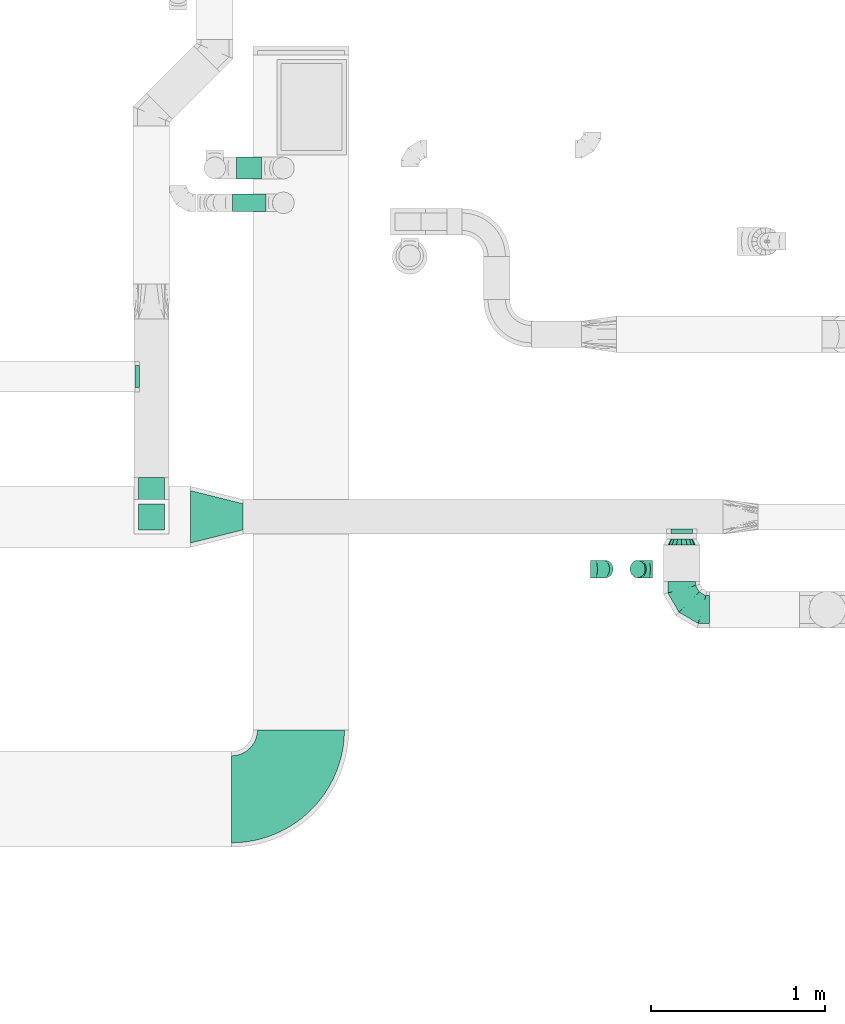
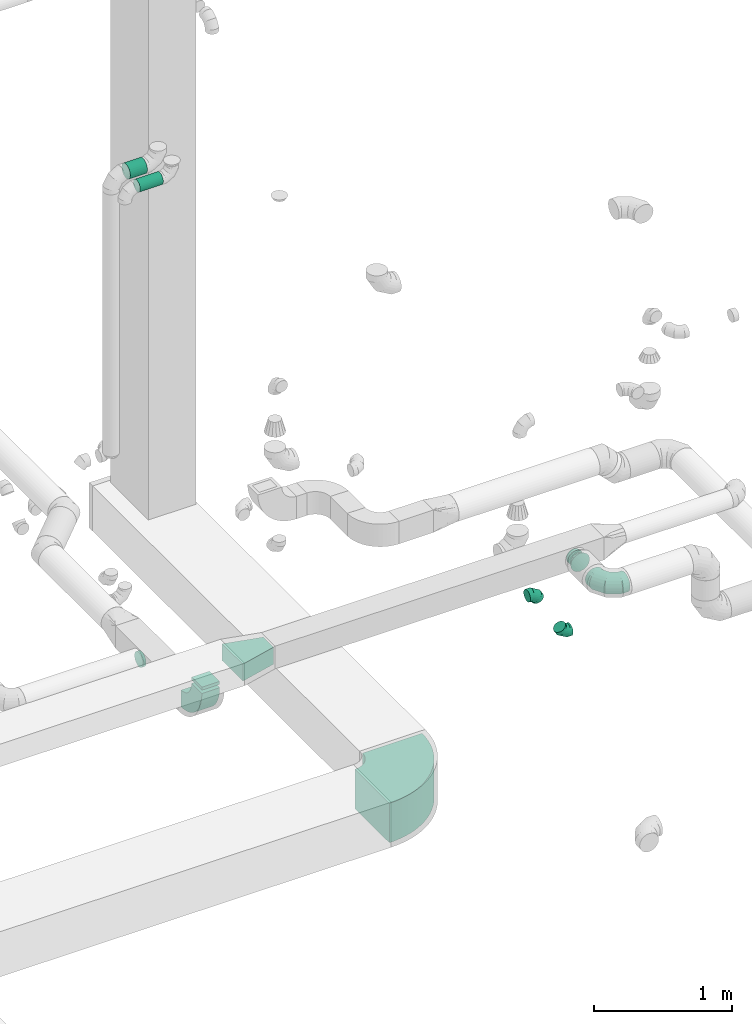
# One storey, part 72 of 97: 10 flow fittings, 2 flow segments.
"""IFC2X3 building model written with IfcOpenShell, lengths in millimetres."""

import ifcopenshell
import ifcopenshell.guid

model = None  # the IFC model being written
_history = None  # IfcOwnerHistory: only IFC2X3 demands one
_inside = {}  # id of a spatial element -> (the spatial element, [elements in it])
_under = {}  # id of a project, library or spatial element -> (it, [spatial elements below it])
_declared = {}  # id of a project -> (the project, [libraries it declares])
_typed = {}  # id of a type object -> (the type object, [elements of that type])
_made_of = {}  # id of a material, layer set ... -> (it, [elements and type objects made of it])


def new_model(schema):
    """Start an empty IFC model of exactly this schema.

    Asked for "IFC4X3", IfcOpenShell would pick the latest addendum, in which some entities
    have other attributes; the version numbers below select the first issue.
    IFC2X3 requires an IfcOwnerHistory on every rooted entity: one is made here for all.
    """
    global model, _history
    if schema == "IFC4X3":
        model = ifcopenshell.file(schema_version=(4, 3, 0, 0))
    else:
        model = ifcopenshell.file(schema=schema)
    _inside.clear()
    _under.clear()
    _declared.clear()
    _typed.clear()
    _made_of.clear()
    _history = None
    if model.schema == "IFC2X3":
        org = make("IfcOrganization", Name="unknown")
        user = make(
            "IfcPersonAndOrganization",
            ThePerson=make("IfcPerson", FamilyName="unknown"),
            TheOrganization=org,
        )
        app = make(
            "IfcApplication",
            ApplicationDeveloper=org,
            Version="unknown",
            ApplicationFullName="unknown",
            ApplicationIdentifier="unknown",
        )
        _history = make(
            "IfcOwnerHistory",
            OwningUser=user,
            OwningApplication=app,
            ChangeAction="ADDED",
            CreationDate=0,
        )
    return model


def make(cls, **values):
    """One entity of the class cls with the attributes given. An attribute that is None is left unset."""
    return model.create_entity(
        cls, **{name: value for name, value in values.items() if value is not None}
    )


def entity(cls, *values):
    """Any entity or typed value of the class cls, its attributes in the order of the schema. None: left unset."""
    e = model.create_entity(cls)
    for i, value in enumerate(values):
        if value is not None:
            e[i] = value
    return e


def rooted(cls, **values):
    """An entity with a GlobalId (a new one), such as an element, a storey or a relation."""
    return make(cls, GlobalId=ifcopenshell.guid.new(), OwnerHistory=_history, **values)


def si_unit(unit_type, name, prefix=None):
    """IfcSIUnit, for example si_unit("LENGTHUNIT", "METRE", prefix="MILLI")."""
    return make("IfcSIUnit", UnitType=unit_type, Prefix=prefix, Name=name)


def converted_unit(unit_type, name, factor, base, dimensions=None, offset=None):
    """IfcConversionBasedUnit, such as the inch: factor (a typed value) times the base unit."""
    return make(
        "IfcConversionBasedUnit"
        if offset is None
        else "IfcConversionBasedUnitWithOffset",
        ConversionOffset=offset,
        Dimensions=None
        if dimensions is None
        else entity("IfcDimensionalExponents", *dimensions),
        UnitType=unit_type,
        Name=name,
        ConversionFactor=make(
            "IfcMeasureWithUnit", ValueComponent=factor, UnitComponent=base
        ),
    )


def derived_unit(unit_type, elements):
    """IfcDerivedUnit: a product of units, each with its exponent."""
    return make(
        "IfcDerivedUnit",
        Elements=[
            make("IfcDerivedUnitElement", Unit=unit, Exponent=power)
            for unit, power in elements
        ],
        UnitType=unit_type,
    )


def assignment(units):
    """IfcUnitAssignment: the units of a project."""
    return None if units is None else make("IfcUnitAssignment", Units=units)


def point(xyz):
    """IfcCartesianPoint."""
    return None if xyz is None else make("IfcCartesianPoint", Coordinates=xyz)


def direction(xyz):
    """IfcDirection."""
    return None if xyz is None else make("IfcDirection", DirectionRatios=xyz)


def frame(location, z_axis=None, x_axis=None):
    """IfcAxis2Placement3D, a coordinate frame: its origin and axes. An axis left out is left unset."""
    return make(
        "IfcAxis2Placement3D",
        Location=point(location),
        Axis=direction(z_axis),
        RefDirection=direction(x_axis),
    )


def frame_2d(location, x_axis=None):
    """IfcAxis2Placement2D, a coordinate frame in the plane: its origin and x axis."""
    return make(
        "IfcAxis2Placement2D", Location=point(location), RefDirection=direction(x_axis)
    )


def origin():
    """The frame at (0, 0, 0) with its axes left unset."""
    return frame((0.0, 0.0, 0.0))


def origin_2d_with_axis():
    """The frame at (0, 0) in the plane with the x axis (1, 0) written out."""
    return frame_2d((0.0, 0.0), x_axis=(1.0, 0.0))


def place(relative_to, where):
    """IfcLocalPlacement: puts the frame where relative to a parent placement (None: the world)."""
    return make(
        "IfcLocalPlacement", PlacementRelTo=relative_to, RelativePlacement=where
    )


def context(
    kind, dimensions, precision=None, world=None, true_north=None, identifier=None
):
    """IfcGeometricRepresentationContext, for example the 3D "Model" context."""
    return make(
        "IfcGeometricRepresentationContext",
        ContextIdentifier=identifier,
        ContextType=kind,
        CoordinateSpaceDimension=dimensions,
        Precision=precision,
        WorldCoordinateSystem=world,
        TrueNorth=true_north,
    )


def subcontext(parent, identifier, kind, view, scale=None):
    """IfcGeometricRepresentationSubContext, for example "Body" below "Model"."""
    return make(
        "IfcGeometricRepresentationSubContext",
        ContextIdentifier=identifier,
        ContextType=kind,
        ParentContext=parent,
        TargetScale=scale,
        TargetView=view,
    )


def project(units=None, contexts=None):
    """IfcProject with its units and contexts."""
    return rooted(
        "IfcProject",
        Name="project",
        RepresentationContexts=contexts,
        UnitsInContext=assignment(units),
    )


def spatial(cls, under=None, at=None, **own):
    """A site, building, storey or space (cls), placed at a placement, below another one or the project."""
    s = rooted(cls, ObjectPlacement=at, **own)
    if under is not None:
        _under.setdefault(under.id(), (under, []))[1].append(s)
    return s


def polyline(points):
    """IfcPolyline through the points."""
    return make("IfcPolyline", Points=[point(p) for p in points])


def circle_curve(where, radius):
    """IfcCircle in the frame where."""
    return make("IfcCircle", Position=where, Radius=radius)


def parameter(value):
    """IfcParameterValue: where a trimmed curve begins or ends, as a parameter of its basis curve."""
    return model.create_entity("IfcParameterValue", value)


def trimmed(basis, trim1, trim2, sense, master):
    """IfcTrimmedCurve: the piece of a basis curve between two trims."""
    return make(
        "IfcTrimmedCurve",
        BasisCurve=basis,
        Trim1=trim1,
        Trim2=trim2,
        SenseAgreement=sense,
        MasterRepresentation=master,
    )


def segment(curve, same_sense, transition):
    """IfcCompositeCurveSegment."""
    return make(
        "IfcCompositeCurveSegment",
        Transition=transition,
        SameSense=same_sense,
        ParentCurve=curve,
    )


def composite_curve(segments, self_intersect=None):
    """IfcCompositeCurve: segments joined end to end."""
    return make("IfcCompositeCurve", Segments=segments, SelfIntersect=self_intersect)


def profile(cls, at=None, kind="AREA", **sizes):
    """A parametric profile (cls). Its sizes go by their IFC names, for example OverallWidth=200.0."""
    return make(cls, ProfileType=kind, Position=at, **sizes)


def rectangle(**sizes):
    """IfcRectangleProfileDef."""
    return profile("IfcRectangleProfileDef", **sizes)


def circle(**sizes):
    """IfcCircleProfileDef."""
    return profile("IfcCircleProfileDef", **sizes)


def outline(outer, holes=None, kind="AREA"):
    """IfcArbitraryClosedProfileDef: a profile drawn as a closed curve; with holes, ...WithVoids."""
    if holes is None:
        return make("IfcArbitraryClosedProfileDef", ProfileType=kind, OuterCurve=outer)
    return make(
        "IfcArbitraryProfileDefWithVoids",
        ProfileType=kind,
        OuterCurve=outer,
        InnerCurves=holes,
    )


def extrude(swept, where, along, depth):
    """IfcExtrudedAreaSolid: the profile swept, set in the frame where, extruded along a direction by depth."""
    return make(
        "IfcExtrudedAreaSolid",
        SweptArea=swept,
        Position=where,
        ExtrudedDirection=direction(along),
        Depth=depth,
    )


def faces_of(points, faces, orient=None, outer=None):
    """IfcFace entities. A face is a list of loops; a loop is a list of indices into points, from 0.

    orient and outer hold one flag for each loop. By default every Orientation is true, the
    first loop of a face is its IfcFaceOuterBound and the others are IfcFaceBound.
    """
    made = []
    for i, loops in enumerate(faces):
        bounds = []
        for j, loop in enumerate(loops):
            is_outer = j == 0 if outer is None else outer[i][j]
            bounds.append(
                make(
                    "IfcFaceOuterBound" if is_outer else "IfcFaceBound",
                    Bound=make("IfcPolyLoop", Polygon=[points[k] for k in loop]),
                    Orientation=True if orient is None else orient[i][j],
                )
            )
        made.append(make("IfcFace", Bounds=bounds))
    return made


def faceted_brep(points, faces, orient=None, outer=None, voids=None):
    """IfcFacetedBrep: a solid bounded by flat faces; with voids (closed shells), ...WithVoids."""
    shared = [point(p) for p in points]
    hull = make("IfcClosedShell", CfsFaces=faces_of(shared, faces, orient, outer))
    if voids is None:
        return make("IfcFacetedBrep", Outer=hull)
    return make(
        "IfcFacetedBrepWithVoids",
        Outer=hull,
        Voids=[
            make(cls, CfsFaces=faces_of(shared, fs, o, b)) for cls, fs, o, b in voids
        ],
    )


def shape(context_of_items, identifier, shape_type, items):
    """IfcShapeRepresentation: the items that make up one representation, for example the "Body"."""
    return make(
        "IfcShapeRepresentation",
        ContextOfItems=context_of_items,
        RepresentationIdentifier=identifier,
        RepresentationType=shape_type,
        Items=items,
    )


def source(mapping_origin, context_of_items, identifier, shape_type, items):
    """IfcRepresentationMap: a shape defined once, which mapped items show again and again."""
    return make(
        "IfcRepresentationMap",
        MappingOrigin=mapping_origin,
        MappedRepresentation=shape(context_of_items, identifier, shape_type, items),
    )


def transform(
    local_origin,
    x_axis=None,
    y_axis=None,
    z_axis=None,
    scale=None,
    scale2=None,
    scale3=None,
    uniform=True,
):
    """IfcCartesianTransformationOperator3D, or its non-uniform kind. x_axis, y_axis, z_axis: its Axis1, 2, 3."""
    if uniform:
        return make(
            "IfcCartesianTransformationOperator3D",
            Axis1=direction(x_axis),
            Axis2=direction(y_axis),
            LocalOrigin=point(local_origin),
            Scale=scale,
            Axis3=direction(z_axis),
        )
    return make(
        "IfcCartesianTransformationOperator3DnonUniform",
        Axis1=direction(x_axis),
        Axis2=direction(y_axis),
        LocalOrigin=point(local_origin),
        Scale=scale,
        Axis3=direction(z_axis),
        Scale2=scale2,
        Scale3=scale3,
    )


def mapped(mapping_source, mapping_target):
    """IfcMappedItem: shows the shape of a source again, moved by a transform."""
    return make(
        "IfcMappedItem", MappingSource=mapping_source, MappingTarget=mapping_target
    )


def material(Name=None, Category=None):
    """IfcMaterial."""
    return make("IfcMaterial", Name=Name, Category=Category)


def made_of(thing, what):
    """Note that an element or type object is made of a material, layer set ...; save() writes the relation."""
    if what is not None:
        _made_of.setdefault(what.id(), (what, []))[1].append(thing)
    return thing


def type_object(cls, material=None, **own):
    """A type object (cls), such as IfcWallType, which elements share."""
    return made_of(rooted(cls, **own), material)


def type_shapes(of_type, sources):
    """Give a type object the sources (RepresentationMaps) that its elements show as mapped items."""
    of_type.RepresentationMaps = sources


def element(
    cls,
    number,
    at=None,
    inside=None,
    cuts=None,
    type_object=None,
    material=None,
    context=None,
    identifier="Body",
    shape_type=None,
    held_by="IfcProductDefinitionShape",
    body=None,
    shapes=None,
    **own,
):
    """One element of the class cls, such as IfcWall. Its Tag is "e" and its number.

    at: its placement. inside: the storey or other place that contains it. cuts: it is an
    opening in that element (IfcRelVoidsElement). A single representation is given by context,
    identifier, shape_type and body (its items); several are given by shapes. held_by: the class
    of the entity that holds the representations. save() writes the other relations.
    """
    e = rooted(cls, Tag="e%d" % number, ObjectPlacement=at, **own)
    if body is not None:
        shapes = [shape(context, identifier, shape_type, body)]
    if shapes is not None:
        e.Representation = make(held_by, Representations=shapes)
    if inside is not None:
        _inside.setdefault(inside.id(), (inside, []))[1].append(e)
    if cuts is not None:
        rooted(
            "IfcRelVoidsElement", RelatingBuildingElement=cuts, RelatedOpeningElement=e
        )
    if type_object is not None:
        _typed.setdefault(type_object.id(), (type_object, []))[1].append(e)
    return made_of(e, material)


def aggregate(whole, parts):
    """IfcRelAggregates: a whole, such as a stair, and the parts it consists of."""
    return rooted("IfcRelAggregates", RelatingObject=whole, RelatedObjects=parts)


def save(model, path):
    """Write the relations noted so far, then the file.

    IfcRelAggregates (storeys below a building ...), IfcRelContainedInSpatialStructure (elements
    in a storey), IfcRelDefinesByType, IfcRelAssociatesMaterial and IfcRelDeclares: one each for
    every whole, place, type object, material and project.
    """
    for whole, parts in _under.values():
        aggregate(whole, parts)
    for where, things in _inside.values():
        rooted(
            "IfcRelContainedInSpatialStructure",
            RelatedElements=things,
            RelatingStructure=where,
        )
    for kind, things in _typed.values():
        rooted("IfcRelDefinesByType", RelatedObjects=things, RelatingType=kind)
    for what, things in _made_of.values():
        rooted("IfcRelAssociatesMaterial", RelatedObjects=things, RelatingMaterial=what)
    for by, libraries in _declared.values():
        rooted("IfcRelDeclares", RelatingContext=by, RelatedDefinitions=libraries)
    model.write(path)


model = new_model("IFC2X3")

# Units and contexts
model_context = context("Model", 3, precision=0.01, world=origin(), true_north=direction((6.12303176911189e-17, 1.0)))
body_context = subcontext(model_context, "Body", "Model", "MODEL_VIEW")
ifc_project = project(units=[si_unit("LENGTHUNIT", "METRE", prefix="MILLI"), si_unit("AREAUNIT", "SQUARE_METRE"), si_unit("VOLUMEUNIT", "CUBIC_METRE"), converted_unit("PLANEANGLEUNIT", "DEGREE", entity("IfcRatioMeasure", 0.0174532925199433), si_unit("PLANEANGLEUNIT", "RADIAN"), dimensions=[0, 0, 0, 0, 0, 0, 0]), si_unit("MASSUNIT", "GRAM", prefix="KILO"), derived_unit("MASSDENSITYUNIT", [(si_unit("MASSUNIT", "GRAM", prefix="KILO"), 1), (si_unit("LENGTHUNIT", "METRE"), -3)]), derived_unit("MOMENTOFINERTIAUNIT", [(si_unit("LENGTHUNIT", "METRE"), 4)]), si_unit("TIMEUNIT", "SECOND"), si_unit("FREQUENCYUNIT", "HERTZ"), si_unit("THERMODYNAMICTEMPERATUREUNIT", "DEGREE_CELSIUS"), derived_unit("THERMALTRANSMITTANCEUNIT", [(si_unit("MASSUNIT", "GRAM", prefix="KILO"), 1), (si_unit("THERMODYNAMICTEMPERATUREUNIT", "KELVIN"), -1), (si_unit("TIMEUNIT", "SECOND"), -3)]), derived_unit("VOLUMETRICFLOWRATEUNIT", [(si_unit("LENGTHUNIT", "METRE"), 3), (si_unit("TIMEUNIT", "SECOND"), -1)]), derived_unit("MASSFLOWRATEUNIT", [(si_unit("MASSUNIT", "GRAM", prefix="KILO"), 1), (si_unit("TIMEUNIT", "SECOND"), -1)]), derived_unit("ROTATIONALFREQUENCYUNIT", [(si_unit("TIMEUNIT", "SECOND"), -1)]), si_unit("ELECTRICCURRENTUNIT", "AMPERE"), si_unit("ELECTRICVOLTAGEUNIT", "VOLT"), si_unit("POWERUNIT", "WATT"), si_unit("FORCEUNIT", "NEWTON", prefix="KILO"), si_unit("ILLUMINANCEUNIT", "LUX"), si_unit("LUMINOUSFLUXUNIT", "LUMEN"), si_unit("LUMINOUSINTENSITYUNIT", "CANDELA"), derived_unit("USERDEFINED", [(si_unit("MASSUNIT", "GRAM", prefix="KILO"), -1), (si_unit("LENGTHUNIT", "METRE"), -2), (si_unit("TIMEUNIT", "SECOND"), 3), (si_unit("LUMINOUSFLUXUNIT", "LUMEN"), 1)]), derived_unit("LINEARVELOCITYUNIT", [(si_unit("LENGTHUNIT", "METRE"), 1), (si_unit("TIMEUNIT", "SECOND"), -1)]), si_unit("PRESSUREUNIT", "PASCAL"), derived_unit("USERDEFINED", [(si_unit("LENGTHUNIT", "METRE"), -2), (si_unit("MASSUNIT", "GRAM", prefix="KILO"), 1), (si_unit("TIMEUNIT", "SECOND"), -2)]), derived_unit("LINEARFORCEUNIT", [(si_unit("MASSUNIT", "GRAM", prefix="KILO"), 1), (si_unit("LENGTHUNIT", "METRE"), 1), (si_unit("TIMEUNIT", "SECOND"), -2), (si_unit("LENGTHUNIT", "METRE"), -1)]), derived_unit("PLANARFORCEUNIT", [(si_unit("MASSUNIT", "GRAM", prefix="KILO"), 1), (si_unit("LENGTHUNIT", "METRE"), 1), (si_unit("TIMEUNIT", "SECOND"), -2), (si_unit("LENGTHUNIT", "METRE"), -2)])], contexts=[model_context])

# Site, building, storey
site_placement = place(None, origin())
site = spatial("IfcSite", under=ifc_project, at=site_placement, CompositionType="ELEMENT")
building_placement = place(site_placement, origin())
building = spatial("IfcBuilding", under=site, at=building_placement, CompositionType="ELEMENT")
storey_placement = place(building_placement, frame((0.0, 0.0, -4900.0)))
storey = spatial("IfcBuildingStorey", under=building, at=storey_placement, CompositionType="ELEMENT", Elevation=-4900.0)

# Flow segments
duct_segment_type = type_object("IfcDuctSegmentType", PredefinedType="NOTDEFINED")
flow_segment_1_placement = place(storey_placement, frame((67594.25, 11926.94, 7348.4)))
element("IfcFlowSegment", 1, at=flow_segment_1_placement, inside=storey, type_object=duct_segment_type, context=body_context, shape_type="SweptSolid", body=[
    extrude(circle(Radius=50.0, at=origin_2d_with_axis()), frame((0.0, 51.6, 51.6), z_axis=(1.0, 0.0, 0.0), x_axis=(0.0, -1.0, 0.0)), (0.0, 0.0, 1.0), 193.744460000044),
])
flow_segment_2_placement = place(storey_placement, frame((67619.25, 12114.64, 7335.9)))
element("IfcFlowSegment", 2, at=flow_segment_2_placement, inside=storey, type_object=duct_segment_type, context=body_context, shape_type="SweptSolid", body=[
    extrude(circle(Radius=62.5, at=origin_2d_with_axis()), frame((0.0, 64.1, 64.1), z_axis=(1.0, 0.0, 0.0), x_axis=(0.0, -1.0, 0.0)), (0.0, 0.0, 1.0), 143.74446000002),
])

# Flow fittings
ifc_material = material()
duct_fitting_type_1 = type_object("IfcDuctFittingType", PredefinedType="NOTDEFINED", material=ifc_material)
shared_shape_1 = source(origin(), body_context, "Body", "SweptSolid", [
    extrude(outline(polyline([(-181.9, -109.14), (127.33, -109.14), (163.71, 36.38), (-109.14, 181.9), (-181.9, -109.14)])), frame((150.0, 0.0, -75.0), z_axis=(0.0, 0.0, 1.0), x_axis=(0.970142500145332, 0.242535625036331, 0.0)), (0.0, 0.0, 1.0), 150.0),
])
type_shapes(duct_fitting_type_1, [shared_shape_1])
flow_fitting_1_placement = place(storey_placement, frame((67355.27, 10174.06, 4350.0)))
element("IfcFlowFitting", 3, at=flow_fitting_1_placement, inside=storey, type_object=duct_fitting_type_1, material=ifc_material, context=body_context, shape_type="MappedRepresentation", body=[
    mapped(shared_shape_1, transform((0.0, 0.0, 0.0), scale=1.0)),
])
duct_fitting_type_2 = type_object("IfcDuctFittingType", PredefinedType="NOTDEFINED", material=ifc_material)
shared_shape_2 = source(origin(), body_context, "Body", "SweptSolid", [
    extrude(rectangle(XDim=26.0960000000062, YDim=150.0, at=origin_2d_with_axis()), frame((6.95, 0.0, -75.0)), (0.0, 0.0, 1.0), 150.0),
])
type_shapes(duct_fitting_type_2, [shared_shape_2])
flow_fitting_2_placement = place(storey_placement, frame((67129.73, 10174.06, 4275.0), z_axis=(0.0, 1.0, 0.0), x_axis=(0.0, 0.0, -1.0)))
element("IfcFlowFitting", 4, at=flow_fitting_2_placement, inside=storey, type_object=duct_fitting_type_2, material=ifc_material, context=body_context, shape_type="MappedRepresentation", body=[
    mapped(shared_shape_2, transform((0.0, 0.0, 0.0), scale=1.0)),
])
duct_fitting_type_3 = type_object("IfcDuctFittingType", PredefinedType="NOTDEFINED", material=ifc_material)
shared_shape_3 = source(origin(), body_context, "Body", "Brep", [
    faceted_brep([(-160.0, 0.0, -80.0), (-160.0, -20.71, -77.27), (-160.0, -40.0, -69.28), (-160.0, -56.57, -56.57), (-160.0, -69.28, -40.0), (-160.0, -77.27, -20.71), (-160.0, -80.0, 0.0), (-160.0, -77.27, 20.71), (-160.0, -69.28, 40.0), (-160.0, -56.57, 56.57), (-160.0, -40.0, 69.28), (-160.0, -20.71, 77.27), (-160.0, 0.0, 80.0), (-160.0, 20.71, 77.27), (-160.0, 40.0, 69.28), (-160.0, 56.57, 56.57), (-160.0, 69.28, 40.0), (-160.0, 77.27, 20.71), (-160.0, 80.0, 0.0), (-160.0, 77.27, -20.71), (-160.0, 69.28, -40.0), (-160.0, 56.57, -56.57), (-160.0, 40.0, -69.28), (-160.0, 20.71, -77.27), (-122.68, 20.71, 77.27), (-127.85, 40.0, 69.28), (-117.13, 0.0, 80.0), (-132.29, 56.57, 56.57), (-137.83, 77.27, 20.71), (-138.56, 80.0, 0.0), (-135.69, 69.28, 40.0), (-135.69, 69.28, -40.0), (-132.29, 56.57, -56.57), (-137.83, 77.27, -20.71), (-122.68, 20.71, -77.27), (-117.13, 0.0, -80.0), (-127.85, 40.0, -69.28), (-111.58, -20.71, -77.27), (-106.41, -40.0, -69.28), (-101.97, -56.57, -56.57), (-98.56, -69.28, -40.0), (-96.42, -77.27, -20.71), (-95.69, -80.0, 0.0), (-96.42, -77.27, 20.71), (-98.56, -69.28, 40.0), (-101.97, -56.57, 56.57), (-106.41, -40.0, 69.28), (-111.58, -20.71, 77.27), (-58.03, 58.03, 77.27), (-72.15, 72.15, 69.28), (-42.87, 42.87, 80.0), (-84.28, 84.28, 56.57), (-93.59, 93.59, 40.0), (-99.44, 99.44, 20.71), (-101.44, 101.44, 0.0), (-99.44, 99.44, -20.71), (-93.59, 93.59, -40.0), (-84.28, 84.28, -56.57), (-58.03, 58.03, -77.27), (-42.87, 42.87, -80.0), (-72.15, 72.15, -69.28), (-27.71, 27.71, -77.27), (-13.59, 13.59, -69.28), (-1.46, 1.46, -56.57), (7.85, -7.85, -40.0), (13.7, -13.7, -20.71), (15.69, -15.69, 0.0), (13.7, -13.7, 20.71), (7.85, -7.85, 40.0), (-1.46, 1.46, 56.57), (-13.59, 13.59, 69.28), (-27.71, 27.71, 77.27), (-20.71, 122.68, 77.27), (-40.0, 127.85, 69.28), (0.0, 117.13, 80.0), (-56.57, 132.29, 56.57), (-69.28, 135.69, 40.0), (-77.27, 137.83, 20.71), (-80.0, 138.56, 0.0), (-77.27, 137.83, -20.71), (-69.28, 135.69, -40.0), (-56.57, 132.29, -56.57), (-20.71, 122.68, -77.27), (0.0, 117.13, -80.0), (-40.0, 127.85, -69.28), (20.71, 111.58, -77.27), (40.0, 106.41, -69.28), (56.57, 101.97, -56.57), (69.28, 98.56, -40.0), (77.27, 96.42, -20.71), (80.0, 95.69, 0.0), (77.27, 96.42, 20.71), (69.28, 98.56, 40.0), (56.57, 101.97, 56.57), (40.0, 106.41, 69.28), (20.71, 111.58, 77.27), (-20.71, 160.0, -77.27), (-40.0, 160.0, -69.28), (-56.57, 160.0, -56.57), (-69.28, 160.0, -40.0), (-77.27, 160.0, -20.71), (-80.0, 160.0, 0.0), (-77.27, 160.0, 20.71), (-69.28, 160.0, 40.0), (-56.57, 160.0, 56.57), (-40.0, 160.0, 69.28), (-20.71, 160.0, 77.27), (0.0, 160.0, 80.0), (20.71, 160.0, 77.27), (40.0, 160.0, 69.28), (56.57, 160.0, 56.57), (69.28, 160.0, 40.0), (77.27, 160.0, 20.71), (80.0, 160.0, 0.0), (77.27, 160.0, -20.71), (69.28, 160.0, -40.0), (56.57, 160.0, -56.57), (40.0, 160.0, -69.28), (20.71, 160.0, -77.27), (0.0, 160.0, -80.0)], [[[0, 1, 2, 3, 4, 5, 6, 7, 8, 9, 10, 11, 12, 13, 14, 15, 16, 17, 18, 19, 20, 21, 22, 23]], [[24, 25, 14, 13]], [[26, 24, 13, 12]], [[14, 25, 27, 15]], [[28, 29, 18, 17]], [[30, 28, 17, 16]], [[15, 27, 30, 16]], [[20, 31, 32, 21]], [[33, 31, 20, 19]], [[18, 29, 33, 19]], [[34, 35, 0, 23]], [[36, 34, 23, 22]], [[32, 36, 22, 21]], [[1, 0, 35, 37]], [[2, 1, 37, 38]], [[3, 2, 38, 39]], [[5, 4, 40, 41]], [[6, 5, 41, 42]], [[39, 40, 4, 3]], [[6, 42, 43, 7]], [[7, 43, 44, 8]], [[8, 44, 45, 9]], [[9, 45, 46, 10]], [[10, 46, 47, 11]], [[26, 12, 11, 47]], [[48, 49, 25, 24]], [[50, 48, 24, 26]], [[27, 25, 49, 51]], [[52, 53, 28, 30]], [[51, 52, 30, 27]], [[29, 28, 53, 54]], [[55, 56, 31, 33]], [[54, 55, 33, 29]], [[32, 31, 56, 57]], [[58, 59, 35, 34]], [[60, 58, 34, 36]], [[57, 60, 36, 32]], [[37, 35, 59, 61]], [[38, 37, 61, 62]], [[39, 38, 62, 63]], [[41, 40, 64, 65]], [[42, 41, 65, 66]], [[63, 64, 40, 39]], [[43, 42, 66, 67]], [[44, 43, 67, 68]], [[68, 69, 45, 44]], [[46, 45, 69, 70]], [[47, 46, 70, 71]], [[26, 47, 71, 50]], [[72, 73, 49, 48]], [[74, 72, 48, 50]], [[51, 49, 73, 75]], [[76, 77, 53, 52]], [[75, 76, 52, 51]], [[54, 53, 77, 78]], [[79, 80, 56, 55]], [[78, 79, 55, 54]], [[57, 56, 80, 81]], [[82, 83, 59, 58]], [[84, 82, 58, 60]], [[81, 84, 60, 57]], [[61, 59, 83, 85]], [[62, 61, 85, 86]], [[63, 62, 86, 87]], [[65, 64, 88, 89]], [[66, 65, 89, 90]], [[87, 88, 64, 63]], [[67, 66, 90, 91]], [[68, 67, 91, 92]], [[92, 93, 69, 68]], [[70, 69, 93, 94]], [[71, 70, 94, 95]], [[50, 71, 95, 74]], [[96, 97, 98, 99, 100, 101, 102, 103, 104, 105, 106, 107, 108, 109, 110, 111, 112, 113, 114, 115, 116, 117, 118, 119]], [[72, 74, 107, 106]], [[73, 72, 106, 105]], [[75, 73, 105, 104]], [[77, 76, 103, 102]], [[78, 77, 102, 101]], [[75, 104, 103, 76]], [[78, 101, 100, 79]], [[79, 100, 99, 80]], [[80, 99, 98, 81]], [[84, 97, 96, 82]], [[82, 96, 119, 83]], [[84, 81, 98, 97]], [[118, 117, 86, 85]], [[119, 118, 85, 83]], [[116, 87, 86, 117]], [[88, 115, 114, 89]], [[89, 114, 113, 90]], [[115, 88, 87, 116]], [[112, 111, 92, 91]], [[113, 112, 91, 90]], [[111, 110, 93, 92]], [[95, 94, 109, 108]], [[74, 95, 108, 107]], [[110, 109, 94, 93]]]),
])
type_shapes(duct_fitting_type_3, [shared_shape_3])
flow_fitting_3_placement = place(storey_placement, frame((70177.23, 9641.0, 4350.0), z_axis=(0.0, 0.0, 1.0), x_axis=(0.0, -1.0, 0.0)))
element("IfcFlowFitting", 5, at=flow_fitting_3_placement, inside=storey, type_object=duct_fitting_type_3, material=ifc_material, context=body_context, shape_type="MappedRepresentation", body=[
    mapped(shared_shape_3, transform((0.0, 0.0, 0.0), scale=1.0)),
])
duct_fitting_type_4 = type_object("IfcDuctFittingType", PredefinedType="NOTDEFINED", material=ifc_material)
shared_shape_4 = source(origin(), body_context, "Body", "Brep", [
    faceted_brep([(20.0, 0.0, -62.5), (20.0, 16.18, -60.37), (20.0, 31.25, -54.13), (20.0, 44.19, -44.19), (20.0, 54.13, -31.25), (20.0, 60.37, -16.18), (20.0, 62.5, 0.0), (20.0, 60.37, 16.18), (20.0, 54.13, 31.25), (20.0, 44.19, 44.19), (20.0, 31.25, 54.13), (20.0, 16.18, 60.37), (20.0, 0.0, 62.5), (20.0, -16.18, 60.37), (20.0, -31.25, 54.13), (20.0, -44.19, 44.19), (20.0, -54.13, 31.25), (20.0, -60.37, 16.18), (20.0, -62.5, 0.0), (20.0, -60.37, -16.18), (20.0, -54.13, -31.25), (20.0, -44.19, -44.19), (20.0, -31.25, -54.13), (20.0, -16.18, -60.37), (0.0, 0.0, 62.5), (-6.1, 0.0, 62.5), (-6.1, -16.18, 60.37), (0.0, -16.18, 60.37), (-6.1, -31.25, 54.13), (0.0, -31.25, 54.13), (0.0, -44.19, 44.19), (-6.1, -44.19, 44.19), (0.0, -54.13, 31.25), (-6.1, -54.13, 31.25), (-6.1, -60.37, 16.18), (0.0, -60.37, 16.18), (-6.1, -62.5, 0.0), (0.0, -62.5, 0.0), (-6.1, -60.37, -16.18), (0.0, -60.37, -16.18), (-6.1, -54.13, -31.25), (0.0, -54.13, -31.25), (0.0, -44.19, -44.19), (-6.1, -44.19, -44.19), (0.0, -31.25, -54.13), (-6.1, -31.25, -54.13), (-6.1, -16.18, -60.37), (0.0, -16.18, -60.37), (-6.1, 0.0, -62.5), (0.0, 0.0, -62.5), (-6.1, 16.18, -60.37), (0.0, 16.18, -60.37), (-6.1, 31.25, -54.13), (0.0, 31.25, -54.13), (0.0, 44.19, -44.19), (-6.1, 44.19, -44.19), (0.0, 54.13, -31.25), (-6.1, 54.13, -31.25), (-6.1, 60.37, -16.18), (0.0, 60.37, -16.18), (-6.1, 62.5, 0.0), (0.0, 62.5, 0.0), (-6.1, 60.37, 16.18), (0.0, 60.37, 16.18), (-6.1, 54.13, 31.25), (0.0, 54.13, 31.25), (0.0, 44.19, 44.19), (-6.1, 44.19, 44.19), (0.0, 31.25, 54.13), (-6.1, 31.25, 54.13), (-6.1, 16.18, 60.37), (0.0, 16.18, 60.37)], [[[0, 1, 2, 3, 4, 5, 6, 7, 8, 9, 10, 11, 12, 13, 14, 15, 16, 17, 18, 19, 20, 21, 22, 23]], [[13, 12, 24, 25, 26, 27]], [[14, 13, 27, 26, 28, 29]], [[30, 15, 14, 29, 28, 31]], [[17, 16, 32, 33, 34, 35]], [[18, 17, 35, 34, 36, 37]], [[32, 16, 15, 30, 31, 33]], [[19, 18, 37, 36, 38, 39]], [[20, 19, 39, 38, 40, 41]], [[42, 21, 20, 41, 40, 43]], [[23, 22, 44, 45, 46, 47]], [[0, 23, 47, 46, 48, 49]], [[44, 22, 21, 42, 43, 45]], [[1, 0, 49, 48, 50, 51]], [[2, 1, 51, 50, 52, 53]], [[54, 3, 2, 53, 52, 55]], [[5, 4, 56, 57, 58, 59]], [[6, 5, 59, 58, 60, 61]], [[56, 4, 3, 54, 55, 57]], [[7, 6, 61, 60, 62, 63]], [[8, 7, 63, 62, 64, 65]], [[66, 9, 8, 65, 64, 67]], [[11, 10, 68, 69, 70, 71]], [[12, 11, 71, 70, 25, 24]], [[68, 10, 9, 66, 67, 69]], [[46, 45, 43, 40, 38, 36, 34, 33, 31, 28, 26, 25, 70, 69, 67, 64, 62, 60, 58, 57, 55, 52, 50, 48]]]),
])
type_shapes(duct_fitting_type_4, [shared_shape_4])
flow_fitting_4_placement = place(storey_placement, frame((67054.73, 10980.22, 4000.0), z_axis=(0.0, 0.0, -1.0), x_axis=(-1.0, 0.0, 0.0)))
element("IfcFlowFitting", 6, at=flow_fitting_4_placement, inside=storey, type_object=duct_fitting_type_4, material=ifc_material, context=body_context, shape_type="MappedRepresentation", body=[
    mapped(shared_shape_4, transform((0.0, 0.0, 0.0), scale=1.0)),
])
duct_fitting_type_5 = type_object("IfcDuctFittingType", PredefinedType="NOTDEFINED", material=ifc_material)
shared_shape_5 = source(origin(), body_context, "Body", "Brep", [
    faceted_brep([(-57.74, 0.0, -50.0), (-57.74, -12.94, -48.3), (-57.74, -25.0, -43.3), (-57.74, -35.36, -35.36), (-57.74, -43.3, -25.0), (-57.74, -48.3, -12.94), (-57.74, -50.0, 0.0), (-57.74, -48.3, 12.94), (-57.74, -43.3, 25.0), (-57.74, -35.36, 35.36), (-57.74, -25.0, 43.3), (-57.74, -12.94, 48.3), (-57.74, 0.0, 50.0), (-57.74, 12.94, 48.3), (-57.74, 25.0, 43.3), (-57.74, 35.36, 35.36), (-57.74, 43.3, 25.0), (-57.74, 48.3, 12.94), (-57.74, 50.0, 0.0), (-57.74, 48.3, -12.94), (-57.74, 43.3, -25.0), (-57.74, 35.36, -35.36), (-57.74, 25.0, -43.3), (-57.74, 12.94, -48.3), (-34.41, 12.94, 48.3), (-37.64, 25.0, 43.3), (-30.94, 0.0, 50.0), (-40.41, 35.36, 35.36), (-43.88, 48.3, 12.94), (-44.34, 50.0, 0.0), (-42.54, 43.3, 25.0), (-42.54, 43.3, -25.0), (-40.41, 35.36, -35.36), (-43.88, 48.3, -12.94), (-34.41, 12.94, -48.3), (-30.94, 0.0, -50.0), (-37.64, 25.0, -43.3), (-27.47, -12.94, -48.3), (-24.24, -25.0, -43.3), (-21.47, -35.36, -35.36), (-19.34, -43.3, -25.0), (-18.0, -48.3, -12.94), (-17.54, -50.0, 0.0), (-18.0, -48.3, 12.94), (-19.34, -43.3, 25.0), (-21.47, -35.36, 35.36), (-24.24, -25.0, 43.3), (-27.47, -12.94, 48.3), (6.0, 36.27, 48.3), (-2.83, 45.1, 43.3), (15.47, 26.79, 50.0), (-10.41, 52.68, 35.36), (-16.23, 58.49, 25.0), (-19.89, 62.15, 12.94), (-21.13, 63.4, 0.0), (-19.89, 62.15, -12.94), (-16.23, 58.49, -25.0), (-10.41, 52.68, -35.36), (6.0, 36.27, -48.3), (15.47, 26.79, -50.0), (-2.83, 45.1, -43.3), (24.94, 17.32, -48.3), (33.77, 8.49, -43.3), (41.35, 0.91, -35.36), (47.17, -4.9, -25.0), (50.83, -8.56, -12.94), (52.07, -9.81, 0.0), (50.83, -8.56, 12.94), (47.17, -4.9, 25.0), (41.35, 0.91, 35.36), (33.77, 8.49, 43.3), (24.94, 17.32, 48.3), (28.87, 50.0, 50.0), (17.66, 56.47, 48.3), (7.22, 62.5, 43.3), (-1.75, 67.68, 35.36), (-8.63, 71.65, 25.0), (-12.96, 74.15, 12.94), (-14.43, 75.0, 0.0), (-12.96, 74.15, -12.94), (-8.63, 71.65, -25.0), (-1.75, 67.68, -35.36), (17.66, 56.47, -48.3), (28.87, 50.0, -50.0), (7.22, 62.5, -43.3), (40.07, 43.53, -48.3), (50.52, 37.5, -43.3), (59.49, 32.32, -35.36), (66.37, 28.35, -25.0), (70.69, 25.85, -12.94), (72.17, 25.0, 0.0), (70.69, 25.85, 12.94), (66.37, 28.35, 25.0), (59.49, 32.32, 35.36), (50.52, 37.5, 43.3), (40.07, 43.53, 48.3)], [[[0, 1, 2, 3, 4, 5, 6, 7, 8, 9, 10, 11, 12, 13, 14, 15, 16, 17, 18, 19, 20, 21, 22, 23]], [[24, 25, 14, 13]], [[26, 24, 13, 12]], [[14, 25, 27, 15]], [[28, 29, 18, 17]], [[30, 28, 17, 16]], [[15, 27, 30, 16]], [[20, 31, 32, 21]], [[33, 31, 20, 19]], [[18, 29, 33, 19]], [[34, 35, 0, 23]], [[36, 34, 23, 22]], [[32, 36, 22, 21]], [[2, 1, 37, 38]], [[3, 2, 38, 39]], [[0, 35, 37, 1]], [[5, 4, 40, 41]], [[6, 5, 41, 42]], [[3, 39, 40, 4]], [[6, 42, 43, 7]], [[7, 43, 44, 8]], [[8, 44, 45, 9]], [[10, 46, 47, 11]], [[11, 47, 26, 12]], [[10, 9, 45, 46]], [[48, 49, 25, 24]], [[50, 48, 24, 26]], [[27, 25, 49, 51]], [[52, 53, 28, 30]], [[51, 52, 30, 27]], [[29, 28, 53, 54]], [[55, 56, 31, 33]], [[54, 55, 33, 29]], [[57, 32, 31, 56]], [[58, 59, 35, 34]], [[60, 58, 34, 36]], [[57, 60, 36, 32]], [[37, 35, 59, 61]], [[38, 37, 61, 62]], [[39, 38, 62, 63]], [[41, 40, 64, 65]], [[42, 41, 65, 66]], [[63, 64, 40, 39]], [[43, 42, 66, 67]], [[44, 43, 67, 68]], [[68, 69, 45, 44]], [[46, 45, 69, 70]], [[47, 46, 70, 71]], [[26, 47, 71, 50]], [[48, 50, 72, 73]], [[49, 48, 73, 74]], [[51, 49, 74, 75]], [[53, 52, 76, 77]], [[54, 53, 77, 78]], [[51, 75, 76, 52]], [[54, 78, 79, 55]], [[55, 79, 80, 56]], [[56, 80, 81, 57]], [[82, 83, 59, 58]], [[84, 82, 58, 60]], [[60, 57, 81, 84]], [[59, 83, 85, 61]], [[61, 85, 86, 62]], [[62, 86, 87, 63]], [[64, 88, 89, 65]], [[65, 89, 90, 66]], [[63, 87, 88, 64]], [[67, 66, 90, 91]], [[68, 67, 91, 92]], [[69, 68, 92, 93]], [[71, 70, 94, 95]], [[50, 71, 95, 72]], [[93, 94, 70, 69]], [[82, 84, 81, 80, 79, 78, 77, 76, 75, 74, 73, 72, 95, 94, 93, 92, 91, 90, 89, 88, 87, 86, 85, 83]]]),
])
type_shapes(duct_fitting_type_5, [shared_shape_5])
for number, where, z_axis, x_axis in (
    (7, (69710.06, 9873.56, 4320.0), (0.0, 1.0, 0.0), (1.0, 0.0, 0.0)),
    (8, (69952.55, 9873.56, 3900.0), (0.0, -1.0, 0.0), (0.499999999999978, 0.0, -0.866025403784451)),
):
    element("IfcFlowFitting", number, at=place(storey_placement, frame(where, z_axis=z_axis, x_axis=x_axis)), inside=storey, type_object=duct_fitting_type_5, material=ifc_material, context=body_context, shape_type="MappedRepresentation", body=[
        mapped(shared_shape_5, transform((0.0, 0.0, 0.0), scale=1.0)),
    ])
duct_fitting_type_6 = type_object("IfcDuctFittingType", PredefinedType="NOTDEFINED", material=ifc_material)
shared_shape_6 = source(origin(), body_context, "Body", "Brep", [
    faceted_brep([(35.0, 0.0, -80.0), (35.0, 12.81, -77.45), (35.0, 30.61, -73.91), (35.0, 43.59, -65.24), (35.0, 56.57, -56.57), (35.0, 65.24, -43.59), (35.0, 73.91, -30.61), (35.0, 76.96, -15.31), (35.0, 80.0, 0.0), (35.0, 77.45, 12.81), (35.0, 73.91, 30.61), (35.0, 65.24, 43.59), (35.0, 56.57, 56.57), (35.0, 43.59, 65.24), (35.0, 30.61, 73.91), (35.0, 15.31, 76.96), (35.0, 0.0, 80.0), (35.0, -12.81, 77.45), (35.0, -30.61, 73.91), (35.0, -43.59, 65.24), (35.0, -56.57, 56.57), (35.0, -65.24, 43.59), (35.0, -73.91, 30.61), (35.0, -76.96, 15.31), (35.0, -80.0, 0.0), (35.0, -77.45, -12.81), (35.0, -73.91, -30.61), (35.0, -65.24, -43.59), (35.0, -56.57, -56.57), (35.0, -43.59, -65.24), (35.0, -30.61, -73.91), (35.0, -15.31, -76.96), (0.0, -23.92, -57.74), (0.0, -34.06, -50.97), (0.0, -44.19, -44.19), (0.0, -50.97, -34.06), (0.0, -57.74, -23.92), (0.0, -60.12, -11.96), (0.0, -62.5, 0.0), (0.0, -60.12, 11.96), (0.0, -57.74, 23.92), (0.0, -50.97, 34.06), (0.0, -44.19, 44.19), (0.0, -34.06, 50.97), (0.0, -23.92, 57.74), (0.0, -11.96, 60.12), (0.0, 0.0, 62.5), (0.0, 11.96, 60.12), (0.0, 23.92, 57.74), (0.0, 34.06, 50.97), (0.0, 44.19, 44.19), (0.0, 50.97, 34.06), (0.0, 57.74, 23.92), (0.0, 60.12, 11.96), (0.0, 62.5, 0.0), (0.0, 60.12, -11.96), (0.0, 57.74, -23.92), (0.0, 50.97, -34.06), (0.0, 44.19, -44.19), (0.0, 34.06, -50.97), (0.0, 23.92, -57.74), (0.0, 11.96, -60.12), (0.0, 0.0, -62.5), (0.0, -11.96, -60.12)], [[[0, 1, 2, 3, 4, 5, 6, 7, 8, 9, 10, 11, 12, 13, 14, 15, 16, 17, 18, 19, 20, 21, 22, 23, 24, 25, 26, 27, 28, 29, 30, 31]], [[32, 33, 34, 35, 36, 37, 38, 39, 40, 41, 42, 43, 44, 45, 46, 47, 48, 49, 50, 51, 52, 53, 54, 55, 56, 57, 58, 59, 60, 61, 62, 63]], [[10, 9, 8, 54, 53, 52]], [[11, 10, 52, 51, 50, 12]], [[48, 14, 13, 12, 50, 49]], [[46, 16, 15, 14, 48, 47]], [[18, 17, 16, 46, 45, 44]], [[19, 18, 44, 43, 42, 20]], [[40, 22, 21, 20, 42, 41]], [[38, 24, 23, 22, 40, 39]], [[26, 25, 24, 38, 37, 36]], [[27, 26, 36, 35, 34, 28]], [[32, 30, 29, 28, 34, 33]], [[62, 0, 31, 30, 32, 63]], [[2, 1, 0, 62, 61, 60]], [[3, 2, 60, 59, 58, 4]], [[56, 6, 5, 4, 58, 57]], [[54, 8, 7, 6, 56, 55]]]),
])
type_shapes(duct_fitting_type_6, [shared_shape_6])
flow_fitting_5_placement = place(storey_placement, frame((70177.23, 10045.77, 4350.0), z_axis=(0.0, 0.0, 1.0), x_axis=(0.0, -1.0, 0.0)))
element("IfcFlowFitting", 9, at=flow_fitting_5_placement, inside=storey, type_object=duct_fitting_type_6, material=ifc_material, context=body_context, shape_type="MappedRepresentation", body=[
    mapped(shared_shape_6, transform((0.0, 0.0, 0.0), scale=1.0)),
])
duct_fitting_type_7 = type_object("IfcDuctFittingType", PredefinedType="NOTDEFINED", material=ifc_material)
shared_shape_7 = source(origin(), body_context, "Body", "Brep", [
    faceted_brep([(20.0, 16.18, -60.37), (20.0, 31.25, -54.13), (20.0, 44.19, -44.19), (20.0, 54.13, -31.25), (20.0, 60.37, -16.18), (20.0, 62.5, 0.0), (20.0, 60.37, 16.18), (20.0, 54.13, 31.25), (20.0, 44.19, 44.19), (20.0, 31.25, 54.13), (20.0, 16.18, 60.37), (20.0, 0.0, 62.5), (20.0, -16.18, 60.37), (20.0, -31.25, 54.13), (20.0, -44.19, 44.19), (20.0, -54.13, 31.25), (20.0, -60.37, 16.18), (20.0, -62.5, 0.0), (20.0, -60.37, -16.18), (20.0, -54.13, -31.25), (20.0, -44.19, -44.19), (20.0, -31.25, -54.13), (20.0, -16.18, -60.37), (20.0, 0.0, -62.5), (0.0, 0.0, 62.5), (0.0, 16.18, 60.37), (-6.1, 16.18, 60.37), (-6.1, 0.0, 62.5), (0.0, 31.25, 54.13), (-6.1, 31.25, 54.13), (0.0, 44.19, 44.19), (-6.1, 44.19, 44.19), (0.0, 54.13, 31.25), (0.0, 60.37, 16.18), (-6.1, 60.37, 16.18), (-6.1, 54.13, 31.25), (0.0, 62.5, 0.0), (-6.1, 62.5, 0.0), (0.0, 60.37, -16.18), (-6.1, 60.37, -16.18), (0.0, 54.13, -31.25), (-6.1, 54.13, -31.25), (0.0, 44.19, -44.19), (-6.1, 44.19, -44.19), (0.0, 31.25, -54.13), (0.0, 16.18, -60.37), (-6.1, 16.18, -60.37), (-6.1, 31.25, -54.13), (0.0, 0.0, -62.5), (-6.1, 0.0, -62.5), (0.0, -16.18, -60.37), (-6.1, -16.18, -60.37), (0.0, -31.25, -54.13), (-6.1, -31.25, -54.13), (0.0, -44.19, -44.19), (-6.1, -44.19, -44.19), (0.0, -54.13, -31.25), (0.0, -60.37, -16.18), (-6.1, -60.37, -16.18), (-6.1, -54.13, -31.25), (0.0, -62.5, 0.0), (-6.1, -62.5, 0.0), (0.0, -60.37, 16.18), (-6.1, -60.37, 16.18), (0.0, -54.13, 31.25), (-6.1, -54.13, 31.25), (0.0, -44.19, 44.19), (-6.1, -44.19, 44.19), (0.0, -31.25, 54.13), (0.0, -16.18, 60.37), (-6.1, -16.18, 60.37), (-6.1, -31.25, 54.13)], [[[0, 1, 2, 3, 4, 5, 6, 7, 8, 9, 10, 11, 12, 13, 14, 15, 16, 17, 18, 19, 20, 21, 22, 23]], [[24, 11, 10, 25, 26, 27]], [[25, 10, 9, 28, 29, 26]], [[28, 9, 8, 30, 31, 29]], [[32, 7, 6, 33, 34, 35]], [[33, 6, 5, 36, 37, 34]], [[30, 8, 7, 32, 35, 31]], [[36, 5, 4, 38, 39, 37]], [[38, 4, 3, 40, 41, 39]], [[40, 3, 2, 42, 43, 41]], [[44, 1, 0, 45, 46, 47]], [[45, 0, 23, 48, 49, 46]], [[42, 2, 1, 44, 47, 43]], [[48, 23, 22, 50, 51, 49]], [[50, 22, 21, 52, 53, 51]], [[52, 21, 20, 54, 55, 53]], [[56, 19, 18, 57, 58, 59]], [[57, 18, 17, 60, 61, 58]], [[54, 20, 19, 56, 59, 55]], [[60, 17, 16, 62, 63, 61]], [[62, 16, 15, 64, 65, 63]], [[64, 15, 14, 66, 67, 65]], [[68, 13, 12, 69, 70, 71]], [[69, 12, 11, 24, 27, 70]], [[66, 14, 13, 68, 71, 67]], [[49, 51, 53, 55, 59, 58, 61, 63, 65, 67, 71, 70, 27, 26, 29, 31, 35, 34, 37, 39, 41, 43, 47, 46]]]),
])
type_shapes(duct_fitting_type_7, [shared_shape_7])
flow_fitting_6_placement = place(storey_placement, frame((70177.23, 10099.06, 4350.0), z_axis=(0.0, 0.0, -1.0), x_axis=(0.0, -1.0, 0.0)))
element("IfcFlowFitting", 10, at=flow_fitting_6_placement, inside=storey, type_object=duct_fitting_type_7, material=ifc_material, context=body_context, shape_type="MappedRepresentation", body=[
    mapped(shared_shape_7, transform((0.0, 0.0, 0.0), scale=1.0)),
])
duct_fitting_type_8 = type_object("IfcDuctFittingType", PredefinedType="NOTDEFINED", material=ifc_material)
shared_shape_8 = source(origin(), body_context, "Body", "SweptSolid", [
    extrude(outline(composite_curve([segment(polyline([(-450.0, -200.0), (50.0, -200.0)]), True, "CONTINUOUS"), segment(trimmed(circle_curve(frame_2d((200.0, -200.0), x_axis=(0.0, 1.0)), 150.0), [parameter(0.0)], [parameter(90.0000000000001)], True, "PARAMETER"), False, "CONTINUOUS"), segment(polyline([(200.0, -50.0), (200.0, 450.0)]), True, "CONTINUOUS"), segment(trimmed(circle_curve(frame_2d((200.0, -200.0), x_axis=(0.0, 1.0)), 650.0), [parameter(0.0)], [parameter(90.0000000000001)], True, "PARAMETER"), True, "CONTINUOUS")], self_intersect=False)), frame((-200.0, 200.0, -175.0), z_axis=(0.0, 0.0, 1.0), x_axis=(-1.0, 0.0, 0.0)), (0.0, 0.0, 1.0), 350.0),
])
type_shapes(duct_fitting_type_8, [shared_shape_8])
flow_fitting_7_placement = place(storey_placement, frame((67989.12, 8550.37, 3980.0)))
element("IfcFlowFitting", 11, at=flow_fitting_7_placement, inside=storey, type_object=duct_fitting_type_8, material=ifc_material, context=body_context, shape_type="MappedRepresentation", body=[
    mapped(shared_shape_8, transform((0.0, 0.0, 0.0), scale=1.0)),
])
duct_fitting_type_9 = type_object("IfcDuctFittingType", PredefinedType="NOTDEFINED", material=ifc_material)
shared_shape_9 = source(origin(), body_context, "Body", "SweptSolid", [
    extrude(outline(composite_curve([segment(polyline([(-187.5, -112.5), (-37.5, -112.5)]), True, "CONTINUOUS"), segment(trimmed(circle_curve(frame_2d((112.5, -112.5), x_axis=(0.0, 1.0)), 150.0), [parameter(0.0)], [parameter(90.0000000000001)], True, "PARAMETER"), False, "CONTINUOUS"), segment(polyline([(112.5, 37.5), (112.5, 187.5)]), True, "CONTINUOUS"), segment(trimmed(circle_curve(frame_2d((112.5, -112.5), x_axis=(0.0, 1.0)), 300.0), [parameter(0.0)], [parameter(90.0000000000001)], True, "PARAMETER"), True, "CONTINUOUS")], self_intersect=False)), frame((-112.5, 112.5, -75.0), z_axis=(0.0, 0.0, 1.0), x_axis=(-1.0, 0.0, 0.0)), (0.0, 0.0, 1.0), 150.0),
])
type_shapes(duct_fitting_type_9, [shared_shape_9])
flow_fitting_8_placement = place(storey_placement, frame((67129.73, 10174.06, 4000.0), z_axis=(-1.0, 0.0, 0.0), x_axis=(0.0, -1.0, 0.0)))
element("IfcFlowFitting", 12, at=flow_fitting_8_placement, inside=storey, type_object=duct_fitting_type_9, material=ifc_material, context=body_context, shape_type="MappedRepresentation", body=[
    mapped(shared_shape_9, transform((0.0, 0.0, 0.0), scale=1.0)),
])

save(model, "model.ifc")
